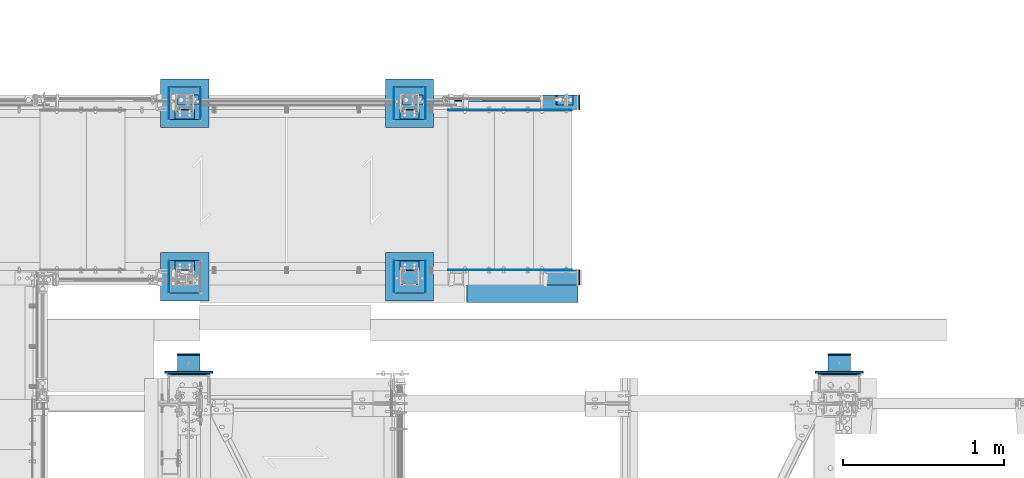
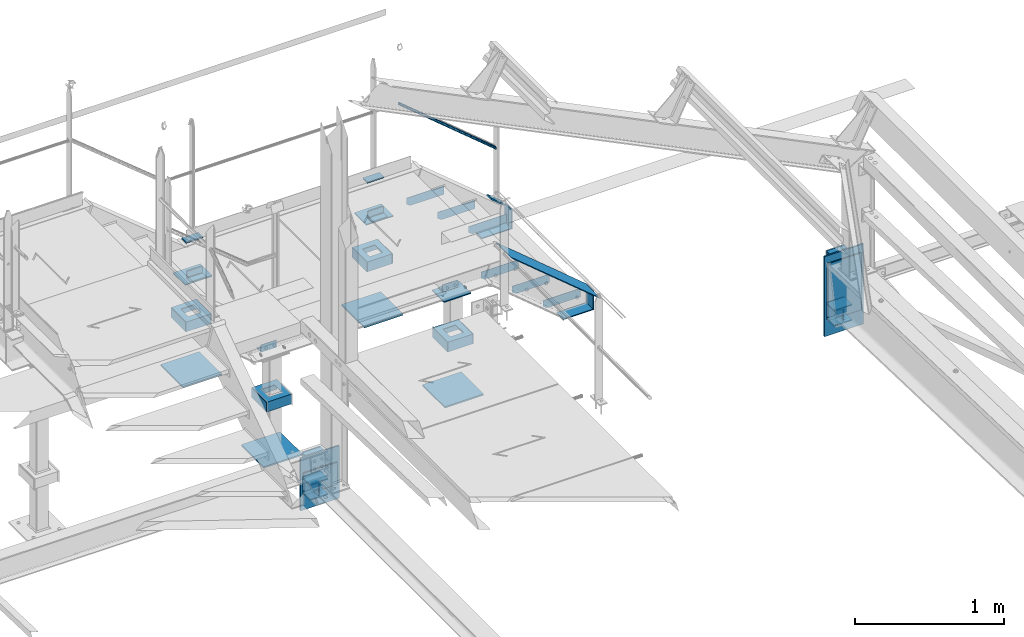
# One storey, part 114 of 496: 46 beams, 3 members, 19 elements without a shape of their own.
"""IFC2X3 building model written with IfcOpenShell, lengths in millimetres."""

from ifc_helpers import new_model, si_unit, frame, origin_with_axes, origin_2d_with_axis, place, context, subcontext, project, spatial, polyline, rectangle, hollow_circle, i_section, l_section, u_section, outline, extrude, boolean, clip, halfspace, material, type_object, element, aggregate, save


model = new_model("IFC2X3")

# Units and contexts
model_context = context("Model", 3, precision=1e-05, world=origin_with_axes())
body_context = subcontext(model_context, "Body", "Model", "MODEL_VIEW")
ifc_project = project(units=[si_unit("LENGTHUNIT", "METRE", prefix="MILLI"), si_unit("AREAUNIT", "SQUARE_METRE"), si_unit("VOLUMEUNIT", "CUBIC_METRE"), si_unit("MASSUNIT", "GRAM", prefix="KILO"), si_unit("TIMEUNIT", "SECOND"), si_unit("PLANEANGLEUNIT", "RADIAN"), si_unit("SOLIDANGLEUNIT", "STERADIAN"), si_unit("THERMODYNAMICTEMPERATUREUNIT", "DEGREE_CELSIUS"), si_unit("LUMINOUSINTENSITYUNIT", "LUMEN")], contexts=[model_context])

# Site, building, storey
site_placement = place(None, origin_with_axes())
site = spatial("IfcSite", under=ifc_project, at=site_placement, CompositionType="ELEMENT")
building_placement = place(site_placement, origin_with_axes())
building = spatial("IfcBuilding", under=site, at=building_placement, Name="Undefined", CompositionType="ELEMENT")
storey_placement = place(building_placement, origin_with_axes())
storey = spatial("IfcBuildingStorey", under=building, at=storey_placement, Name="Undefined", CompositionType="ELEMENT", Elevation=0.0)

# Assembly, member
assembly_1_placement = place(storey_placement, origin_with_axes())
assembly_1 = element("IfcElementAssembly", 1, at=assembly_1_placement, inside=storey, Name="VIDE", AssemblyPlace="NOTDEFINED", PredefinedType="NOTDEFINED")
ifc_material_1 = material(Name="Undefined/S235-E24")
member_type_1 = type_object("IfcMemberType", PredefinedType="NOTDEFINED")
member_1_placement = place(assembly_1_placement, frame((36702.1608014901, 15929.9998774163, 7532.9377228811), z_axis=(0.0, -1.0, 0.0), x_axis=(-0.768221279597376, 0.0, 0.640184399664479)))
member_1 = element("IfcMember", 2, at=member_1_placement, type_object=member_type_1, material=ifc_material_1, Name="VIDE", context=body_context, shape_type="SweptSolid", body=[
    extrude(rectangle(XDim=6.0, YDim=200.0, at=origin_2d_with_axis()), frame((900.000000001432, 9.99200722164227e-14, 0.0), z_axis=(-1.0, 0.0, 0.0), x_axis=(0.0, -1.0, 0.0)), (0.0, 0.0, 1.0), 900.0),
])
aggregate(assembly_1, [member_1])

# Assembly, beams, member
assembly_2_placement = place(storey_placement, origin_with_axes())
assembly_2 = element("IfcElementAssembly", 3, at=assembly_2_placement, inside=storey, Name="MAIN COURANTE", AssemblyPlace="NOTDEFINED", PredefinedType="NOTDEFINED")
beam_type_1 = type_object("IfcBeamType", PredefinedType="NOTDEFINED")
beam_1_placement = place(assembly_2_placement, frame((35740.0061849194, 17089.9938659712, 8114.9999407569), z_axis=(0.0, 1.0, 0.0), x_axis=(-1.0, 0.0, 0.0)))
beam_1 = element("IfcBeam", 4, at=beam_1_placement, type_object=beam_type_1, material=ifc_material_1, context=body_context, shape_type="SweptSolid", body=[
    extrude(rectangle(XDim=10.0, YDim=60.0, at=origin_2d_with_axis()), frame((130.0, 0.0, 0.0), z_axis=(-1.0, 0.0, 0.0), x_axis=(0.0, -1.0, 0.0)), (0.0, 0.0, 1.0), 130.0),
])
beam_2_placement = place(assembly_2_placement, frame((34340.0061849194, 17089.9938659712, 8114.9999407569), z_axis=(0.0, 1.0, 0.0), x_axis=(-1.0, 0.0, 0.0)))
beam_2 = element("IfcBeam", 5, at=beam_2_placement, type_object=beam_type_1, material=ifc_material_1, context=body_context, shape_type="SweptSolid", body=[
    extrude(rectangle(XDim=10.0, YDim=60.0, at=origin_2d_with_axis()), frame((130.0, 0.0, 0.0), z_axis=(-1.0, 0.0, 0.0), x_axis=(0.0, -1.0, 0.0)), (0.0, 0.0, 1.0), 130.0),
])
member_type_2 = type_object("IfcMemberType", PredefinedType="NOTDEFINED")
member_2_placement = place(assembly_2_placement, frame((36625.0061849194, 17089.9898795518, 8025.73196061016), z_axis=(0.0, -1.0, 0.0), x_axis=(-0.768221279597376, 0.0, 0.640184399664479)))
member_2 = element("IfcMember", 6, at=member_2_placement, type_object=member_type_2, material=ifc_material_1, Name="LISSE", context=body_context, shape_type="Clipping", body=[
    clip(clip(extrude(hollow_circle(Radius=10.64999962, WallThickness=2.0, at=origin_2d_with_axis()), frame((999.915375119574, 0.0, 0.0), z_axis=(-1.0, 0.0, 0.0), x_axis=(0.0, -1.0, 0.0)), (0.0, 0.0, 1.0), 1012.25), halfspace(frame((981.073731210257, -1.82259100256488e-07, -0.0039864193968242), z_axis=(-0.940271591821765, -0.340425224701349, 0.0), x_axis=(0.0, 0.0, -1.0)), True)), halfspace(frame((18.5934348061346, -14.5018748797629, -0.0039864193968242), z_axis=(-0.768221329187549, -0.640184340156267, 0.0), x_axis=(0.0, 0.0, -1.0)), False)),
])

# Assembly, beam
assembly_3_placement = place(storey_placement, origin_with_axes())
assembly_3 = element("IfcElementAssembly", 7, at=assembly_3_placement, inside=storey, AssemblyPlace="NOTDEFINED", PredefinedType="NOTDEFINED")
beam_type_2 = type_object("IfcBeamType", PredefinedType="NOTDEFINED")
beam_3_placement = place(assembly_3_placement, frame((34405.0000000001, 15839.9999136253, 7056.0), z_axis=(0.0, 0.0, -1.0), x_axis=(-1.0, 0.0, 0.0)))
beam_3 = element("IfcBeam", 8, at=beam_3_placement, type_object=beam_type_2, material=ifc_material_1, context=body_context, shape_type="SweptSolid", body=[
    extrude(outline(polyline([(0.0, 0.0), (300.0, 0.0), (300.0, 300.0), (0.0, 300.0), (0.0, 0.0)])), frame((0.0, 0.0, -6.0), z_axis=(0.0, 0.0, 1.0), x_axis=(1.0, 0.0, 0.0)), (0.0, 0.0, 1.0), 12.0),
])

assembly_4_placement = place(storey_placement, origin_with_axes())
assembly_4 = element("IfcElementAssembly", 9, at=assembly_4_placement, inside=storey, AssemblyPlace="NOTDEFINED", PredefinedType="NOTDEFINED")
beam_4_placement = place(assembly_4_placement, frame((35805.0000000001, 15839.9999136253, 7056.0), z_axis=(0.0, 0.0, -1.0), x_axis=(-1.0, 0.0, 0.0)))
beam_4 = element("IfcBeam", 10, at=beam_4_placement, type_object=beam_type_2, material=ifc_material_1, context=body_context, shape_type="SweptSolid", body=[
    extrude(outline(polyline([(0.0, 0.0), (300.0, 0.0), (300.0, 300.0), (0.0, 300.0), (0.0, 0.0)])), frame((0.0, 0.0, -6.0), z_axis=(0.0, 0.0, 1.0), x_axis=(1.0, 0.0, 0.0)), (0.0, 0.0, 1.0), 12.0),
])

assembly_5_placement = place(storey_placement, origin_with_axes())
assembly_5 = element("IfcElementAssembly", 11, at=assembly_5_placement, inside=storey, AssemblyPlace="NOTDEFINED", PredefinedType="NOTDEFINED")
beam_5_placement = place(assembly_5_placement, frame((34405.0000000001, 17219.9996684749, 7056.0), z_axis=(0.0, 0.0, 1.0), x_axis=(-1.0, 0.0, 0.0)))
beam_5 = element("IfcBeam", 12, at=beam_5_placement, type_object=beam_type_2, material=ifc_material_1, context=body_context, shape_type="SweptSolid", body=[
    extrude(outline(polyline([(0.0, 0.0), (300.0, 0.0), (300.0, 300.0), (0.0, 300.0), (0.0, 0.0)])), frame((0.0, 0.0, -6.0), z_axis=(0.0, 0.0, 1.0), x_axis=(1.0, 0.0, 0.0)), (0.0, 0.0, 1.0), 12.0),
])

assembly_6_placement = place(storey_placement, origin_with_axes())
assembly_6 = element("IfcElementAssembly", 13, at=assembly_6_placement, inside=storey, AssemblyPlace="NOTDEFINED", PredefinedType="NOTDEFINED")
beam_6_placement = place(assembly_6_placement, frame((35805.0000000001, 17219.9996684749, 7056.0), z_axis=(0.0, 0.0, 1.0), x_axis=(-1.0, 0.0, 0.0)))
beam_6 = element("IfcBeam", 14, at=beam_6_placement, type_object=beam_type_2, material=ifc_material_1, context=body_context, shape_type="SweptSolid", body=[
    extrude(outline(polyline([(0.0, 0.0), (300.0, 0.0), (300.0, 300.0), (0.0, 300.0), (0.0, 0.0)])), frame((0.0, 0.0, -6.0), z_axis=(0.0, 0.0, 1.0), x_axis=(1.0, 0.0, 0.0)), (0.0, 0.0, 1.0), 12.0),
])

assembly_7_placement = place(storey_placement, origin_with_axes())
assembly_7 = element("IfcElementAssembly", 15, at=assembly_7_placement, inside=storey, AssemblyPlace="NOTDEFINED", PredefinedType="NOTDEFINED")
beam_7_placement = place(assembly_7_placement, frame((34280.0000000012, 15395.9999999526, 7394.99830350895), z_axis=(-1.0, 0.0, 0.0), x_axis=(0.0, 0.0, -1.0)))
beam_7 = element("IfcBeam", 16, at=beam_7_placement, type_object=beam_type_2, material=ifc_material_1, context=body_context, shape_type="SweptSolid", body=[
    extrude(rectangle(XDim=12.0, YDim=300.0, at=origin_2d_with_axis()), frame((429.999999999754, 0.0, 0.0), z_axis=(-1.0, 0.0, 0.0), x_axis=(0.0, -1.0, 0.0)), (0.0, 0.0, 1.0), 430.0),
])

assembly_8_placement = place(storey_placement, origin_with_axes())
assembly_8 = element("IfcElementAssembly", 17, at=assembly_8_placement, inside=storey, AssemblyPlace="NOTDEFINED", PredefinedType="NOTDEFINED")
beam_8_placement = place(assembly_8_placement, frame((38330.0000000267, 15396.0000001713, 7624.99830350781), z_axis=(-1.0, 0.0, 0.0), x_axis=(0.0, 0.0, -1.0)))
beam_8 = element("IfcBeam", 18, at=beam_8_placement, type_object=beam_type_2, material=ifc_material_1, context=body_context, shape_type="SweptSolid", body=[
    extrude(rectangle(XDim=12.0, YDim=300.0, at=origin_2d_with_axis()), frame((654.999999999754, 0.0, 0.0), z_axis=(-1.0, 0.0, 0.0), x_axis=(0.0, -1.0, 0.0)), (0.0, 0.0, 1.0), 655.0),
])

# Member
member_type_3 = type_object("IfcMemberType", PredefinedType="NOTDEFINED")
member_3_placement = place(assembly_2_placement, frame((36667.8985396969, 17089.9938659712, 7564.09302426877), z_axis=(0.0, 1.0, 0.0), x_axis=(-0.768221279597376, 0.0, 0.640184399664479)))
member_3 = element("IfcMember", 19, at=member_3_placement, type_object=member_type_3, material=ifc_material_1, context=body_context, shape_type="SweptSolid", body=[
    extrude(rectangle(XDim=10.0, YDim=60.0, at=origin_2d_with_axis()), frame((130.0, 0.0, 0.0), z_axis=(-1.0, 0.0, 0.0), x_axis=(0.0, -1.0, 0.0)), (0.0, 0.0, 1.0), 130.0),
])

aggregate(assembly_2, [member_3, beam_1, beam_2, member_2])

# Beam
beam_type_3 = type_object("IfcBeamType", PredefinedType="NOTDEFINED")
beam_9_placement = place(assembly_4_placement, frame((35760.0000000001, 15930.0004325462, 7846.00001160755), z_axis=(0.0, 0.0, -1.0), x_axis=(-1.0, 0.0, 0.0)))
beam_9 = element("IfcBeam", 20, at=beam_9_placement, type_object=beam_type_3, material=ifc_material_1, context=body_context, shape_type="SweptSolid", body=[
    extrude(outline(polyline([(0.0, 0.0), (210.0, 0.0), (210.0, 159.999481201172), (0.0, 159.999481201172), (0.0, 0.0)])), frame((0.0, 0.0, -4.0), z_axis=(0.0, 0.0, 1.0), x_axis=(1.0, 0.0, 0.0)), (0.0, 0.0, 1.0), 8.0),
])

beam_10_placement = place(assembly_5_placement, frame((34360.0000000001, 17129.9991495539, 7846.00001160755), z_axis=(0.0, 0.0, 1.0), x_axis=(-1.0, 0.0, 0.0)))
beam_10 = element("IfcBeam", 21, at=beam_10_placement, type_object=beam_type_3, material=ifc_material_1, context=body_context, shape_type="SweptSolid", body=[
    extrude(outline(polyline([(0.0, 0.0), (210.0, 0.0), (210.0, 159.999481201172), (0.0, 159.999481201172), (0.0, 0.0)])), frame((0.0, 0.0, -4.0), z_axis=(0.0, 0.0, 1.0), x_axis=(1.0, 0.0, 0.0)), (0.0, 0.0, 1.0), 8.0),
])

beam_11_placement = place(assembly_6_placement, frame((35760.0000000001, 17129.9991495539, 7846.00001160755), z_axis=(0.0, 0.0, 1.0), x_axis=(-1.0, 0.0, 0.0)))
beam_11 = element("IfcBeam", 22, at=beam_11_placement, type_object=beam_type_3, material=ifc_material_1, context=body_context, shape_type="SweptSolid", body=[
    extrude(outline(polyline([(0.0, 0.0), (210.0, 0.0), (210.0, 159.999481201172), (0.0, 159.999481201172), (0.0, 0.0)])), frame((0.0, 0.0, -4.0), z_axis=(0.0, 0.0, 1.0), x_axis=(1.0, 0.0, 0.0)), (0.0, 0.0, 1.0), 8.0),
])

beam_type_4 = type_object("IfcBeamType", PredefinedType="NOTDEFINED")
beam_12_placement = place(assembly_4_placement, frame((35753.0000000001, 16089.9999136253, 7500.0), z_axis=(0.0, 0.0, 1.0), x_axis=(0.0, -1.0, 0.0)))
beam_12 = element("IfcBeam", 23, at=beam_12_placement, type_object=beam_type_4, material=ifc_material_1, Name="BORD", context=body_context, shape_type="SweptSolid", body=[
    extrude(rectangle(XDim=4.0, YDim=80.0, at=origin_2d_with_axis()), frame((200.0, 0.0, 0.0), z_axis=(-1.0, 0.0, 0.0), x_axis=(0.0, -1.0, 0.0)), (0.0, 0.0, 1.0), 200.0),
])

beam_13_placement = place(assembly_3_placement, frame((34157.0000000001, 16089.9999136253, 7500.0), z_axis=(0.0, 0.0, 1.0), x_axis=(0.0, -1.0, 0.0)))
beam_13 = element("IfcBeam", 24, at=beam_13_placement, type_object=beam_type_4, material=ifc_material_1, Name="BORD", context=body_context, shape_type="SweptSolid", body=[
    extrude(rectangle(XDim=4.0, YDim=80.0, at=origin_2d_with_axis()), frame((200.0, 0.0, 0.0), z_axis=(-1.0, 0.0, 0.0), x_axis=(0.0, -1.0, 0.0)), (0.0, 0.0, 1.0), 200.0),
])

beam_14_placement = place(assembly_4_placement, frame((35557.0000000001, 16089.9999136253, 7500.0), z_axis=(0.0, 0.0, 1.0), x_axis=(0.0, -1.0, 0.0)))
beam_14 = element("IfcBeam", 25, at=beam_14_placement, type_object=beam_type_4, material=ifc_material_1, Name="BORD", context=body_context, shape_type="SweptSolid", body=[
    extrude(rectangle(XDim=4.0, YDim=80.0, at=origin_2d_with_axis()), frame((200.0, 0.0, 0.0), z_axis=(-1.0, 0.0, 0.0), x_axis=(0.0, -1.0, 0.0)), (0.0, 0.0, 1.0), 200.0),
])

beam_15_placement = place(assembly_5_placement, frame((34353.0000000001, 16969.9996684749, 7500.0), z_axis=(0.0, 0.0, 1.0), x_axis=(0.0, 1.0, 0.0)))
beam_15 = element("IfcBeam", 26, at=beam_15_placement, type_object=beam_type_4, material=ifc_material_1, Name="BORD", context=body_context, shape_type="SweptSolid", body=[
    extrude(rectangle(XDim=4.0, YDim=80.0, at=origin_2d_with_axis()), frame((200.0, 0.0, 0.0), z_axis=(-1.0, 0.0, 0.0), x_axis=(0.0, -1.0, 0.0)), (0.0, 0.0, 1.0), 200.0),
])

beam_16_placement = place(assembly_6_placement, frame((35753.0000000001, 16969.9996684749, 7500.0), z_axis=(0.0, 0.0, 1.0), x_axis=(0.0, 1.0, 0.0)))
beam_16 = element("IfcBeam", 27, at=beam_16_placement, type_object=beam_type_4, material=ifc_material_1, Name="BORD", context=body_context, shape_type="SweptSolid", body=[
    extrude(rectangle(XDim=4.0, YDim=80.0, at=origin_2d_with_axis()), frame((200.0, 0.0, 0.0), z_axis=(-1.0, 0.0, 0.0), x_axis=(0.0, -1.0, 0.0)), (0.0, 0.0, 1.0), 200.0),
])

beam_17_placement = place(assembly_5_placement, frame((34157.0000000001, 16969.9996684749, 7500.0), z_axis=(0.0, 0.0, 1.0), x_axis=(0.0, 1.0, 0.0)))
beam_17 = element("IfcBeam", 28, at=beam_17_placement, type_object=beam_type_4, material=ifc_material_1, Name="BORD", context=body_context, shape_type="SweptSolid", body=[
    extrude(rectangle(XDim=4.0, YDim=80.0, at=origin_2d_with_axis()), frame((200.0, 0.0, 0.0), z_axis=(-1.0, 0.0, 0.0), x_axis=(0.0, -1.0, 0.0)), (0.0, 0.0, 1.0), 200.0),
])

beam_18_placement = place(assembly_6_placement, frame((35557.0000000001, 16969.9996684749, 7500.0), z_axis=(0.0, 0.0, 1.0), x_axis=(0.0, 1.0, 0.0)))
beam_18 = element("IfcBeam", 29, at=beam_18_placement, type_object=beam_type_4, material=ifc_material_1, Name="BORD", context=body_context, shape_type="SweptSolid", body=[
    extrude(rectangle(XDim=4.0, YDim=80.0, at=origin_2d_with_axis()), frame((200.0, 0.0, 0.0), z_axis=(-1.0, 0.0, 0.0), x_axis=(0.0, -1.0, 0.0)), (0.0, 0.0, 1.0), 200.0),
])

beam_type_5 = type_object("IfcBeamType", PredefinedType="NOTDEFINED")
beam_19_placement = place(assembly_3_placement, frame((34351.0000000001, 15989.9999136253, 7500.0), z_axis=(0.0, 1.0, 0.0), x_axis=(-1.0, 0.0, 0.0)))
beam_19 = element("IfcBeam", 30, at=beam_19_placement, type_object=beam_type_5, material=ifc_material_1, context=body_context, shape_type="CSG", body=[
    boolean("DIFFERENCE", extrude(u_section(Depth=200.0, FlangeWidth=80.0, WebThickness=4.0, FlangeThickness=4.0, at=origin_2d_with_axis()), frame((192.0, 0.0, 0.0), z_axis=(-1.0, 0.0, 0.0), x_axis=(0.0, -1.0, 0.0)), (0.0, 0.0, 1.0), 192.0), extrude(outline(polyline([(0.0, 0.0), (101.0, 0.0), (101.0, 101.0), (0.0, 101.0), (0.0, 0.0)])), frame((146.5, -42.5, 50.5), z_axis=(0.0, 1.0, 0.0), x_axis=(0.0, 0.0, -1.0)), (0.0, 0.0, 1.0), 85.0)),
])

aggregate(assembly_3, [beam_13, beam_19, beam_3])

beam_20_placement = place(assembly_4_placement, frame((35751.0000000001, 15989.9999136253, 7500.0), z_axis=(0.0, 1.0, 0.0), x_axis=(-1.0, 0.0, 0.0)))
beam_20 = element("IfcBeam", 31, at=beam_20_placement, type_object=beam_type_5, material=ifc_material_1, context=body_context, shape_type="CSG", body=[
    boolean("DIFFERENCE", extrude(u_section(Depth=200.0, FlangeWidth=80.0, WebThickness=4.0, FlangeThickness=4.0, at=origin_2d_with_axis()), frame((192.0, 0.0, 0.0), z_axis=(-1.0, 0.0, 0.0), x_axis=(0.0, -1.0, 0.0)), (0.0, 0.0, 1.0), 192.0), extrude(outline(polyline([(0.0, 0.0), (101.0, 0.0), (101.0, 101.0), (0.0, 101.0), (0.0, 0.0)])), frame((146.5, -42.5, 50.5), z_axis=(0.0, 1.0, 0.0), x_axis=(0.0, 0.0, -1.0)), (0.0, 0.0, 1.0), 85.0)),
])

aggregate(assembly_4, [beam_12, beam_9, beam_14, beam_20, beam_4])

beam_21_placement = place(assembly_5_placement, frame((34159.0000000001, 17069.9996684749, 7500.0), z_axis=(0.0, -1.0, 0.0), x_axis=(1.0, 0.0, 0.0)))
beam_21 = element("IfcBeam", 32, at=beam_21_placement, type_object=beam_type_5, material=ifc_material_1, context=body_context, shape_type="CSG", body=[
    boolean("DIFFERENCE", extrude(u_section(Depth=200.0, FlangeWidth=80.0, WebThickness=4.0, FlangeThickness=4.0, at=origin_2d_with_axis()), frame((192.0, 0.0, 0.0), z_axis=(-1.0, 0.0, 0.0), x_axis=(0.0, -1.0, 0.0)), (0.0, 0.0, 1.0), 192.0), extrude(outline(polyline([(0.0, 0.0), (101.0, 0.0), (101.0, 101.0), (0.0, 101.0), (0.0, 0.0)])), frame((45.5, -42.5, -50.5), z_axis=(0.0, 1.0, 0.0), x_axis=(0.0, 0.0, 1.0)), (0.0, 0.0, 1.0), 85.0)),
])

aggregate(assembly_5, [beam_10, beam_15, beam_17, beam_21, beam_5])

beam_22_placement = place(assembly_6_placement, frame((35559.0000000001, 17069.9996684749, 7500.0), z_axis=(0.0, -1.0, 0.0), x_axis=(1.0, 0.0, 0.0)))
beam_22 = element("IfcBeam", 33, at=beam_22_placement, type_object=beam_type_5, material=ifc_material_1, context=body_context, shape_type="CSG", body=[
    boolean("DIFFERENCE", extrude(u_section(Depth=200.0, FlangeWidth=80.0, WebThickness=4.0, FlangeThickness=4.0, at=origin_2d_with_axis()), frame((192.0, 0.0, 0.0), z_axis=(-1.0, 0.0, 0.0), x_axis=(0.0, -1.0, 0.0)), (0.0, 0.0, 1.0), 192.0), extrude(outline(polyline([(0.0, 0.0), (101.0, 0.0), (101.0, 101.0), (0.0, 101.0), (0.0, 0.0)])), frame((45.5, -42.5, -50.5), z_axis=(0.0, 1.0, 0.0), x_axis=(0.0, 0.0, 1.0)), (0.0, 0.0, 1.0), 85.0)),
])

aggregate(assembly_6, [beam_16, beam_11, beam_18, beam_22, beam_6])

# Assembly, beams
assembly_9_placement = place(storey_placement, origin_with_axes())
assembly_9 = element("IfcElementAssembly", 34, at=assembly_9_placement, inside=storey, AssemblyPlace="NOTDEFINED", PredefinedType="NOTDEFINED")
beam_type_6 = type_object("IfcBeamType", PredefinedType="NOTDEFINED")
beam_23_placement = place(assembly_9_placement, frame((36714.9999902344, 15984.9996684858, 7373.99994075732), z_axis=(0.0, -1.0, 0.0), x_axis=(-1.0, 0.0, 0.0)))
beam_23 = element("IfcBeam", 35, at=beam_23_placement, type_object=beam_type_6, material=ifc_material_1, Name="PLAT", context=body_context, shape_type="SweptSolid", body=[
    extrude(rectangle(XDim=8.0, YDim=90.0, at=origin_2d_with_axis()), frame((237.732983147944, 0.0, 0.0), z_axis=(-1.0, 0.0, 0.0), x_axis=(0.0, -1.0, 0.0)), (0.0, 0.0, 1.0), 237.73),
])
beam_24_placement = place(assembly_9_placement, frame((36710.9999902344, 15984.9996684858, 7524.9999407576), z_axis=(0.0, -1.0, 0.0), x_axis=(0.0, 0.0, -1.0)))
beam_24 = element("IfcBeam", 36, at=beam_24_placement, type_object=beam_type_6, material=ifc_material_1, Name="PLAT", context=body_context, shape_type="SweptSolid", body=[
    extrude(rectangle(XDim=8.0, YDim=90.0, at=origin_2d_with_axis()), frame((147.00000000028, 0.0, 0.0), z_axis=(-1.0, 0.0, 0.0), x_axis=(0.0, -1.0, 0.0)), (0.0, 0.0, 1.0), 147.0),
])
aggregate(assembly_9, [beam_23, beam_24])

assembly_10_placement = place(storey_placement, origin_with_axes())
assembly_10 = element("IfcElementAssembly", 37, at=assembly_10_placement, inside=storey, AssemblyPlace="NOTDEFINED", PredefinedType="NOTDEFINED")
beam_25_placement = place(assembly_10_placement, frame((36714.9999902344, 17074.9996684893, 7373.99994075732), z_axis=(0.0, 1.0, 0.0), x_axis=(-1.0, 0.0, 0.0)))
beam_25 = element("IfcBeam", 38, at=beam_25_placement, type_object=beam_type_6, material=ifc_material_1, Name="PLAT", context=body_context, shape_type="SweptSolid", body=[
    extrude(rectangle(XDim=8.0, YDim=90.0, at=origin_2d_with_axis()), frame((237.732983147944, 0.0, 0.0), z_axis=(-1.0, 0.0, 0.0), x_axis=(0.0, -1.0, 0.0)), (0.0, 0.0, 1.0), 237.73),
])
beam_26_placement = place(assembly_10_placement, frame((36710.9999902344, 17074.9996684893, 7524.9999407576), z_axis=(0.0, 1.0, 0.0), x_axis=(0.0, 0.0, -1.0)))
beam_26 = element("IfcBeam", 39, at=beam_26_placement, type_object=beam_type_6, material=ifc_material_1, Name="PLAT", context=body_context, shape_type="SweptSolid", body=[
    extrude(rectangle(XDim=8.0, YDim=90.0, at=origin_2d_with_axis()), frame((147.00000000028, 0.0, 0.0), z_axis=(-1.0, 0.0, 0.0), x_axis=(0.0, -1.0, 0.0)), (0.0, 0.0, 1.0), 147.0),
])
aggregate(assembly_10, [beam_25, beam_26])

assembly_11_placement = place(storey_placement, origin_with_axes())
assembly_11 = element("IfcElementAssembly", 40, at=assembly_11_placement, inside=storey, Name="MARCHE", AssemblyPlace="NOTDEFINED", PredefinedType="NOTDEFINED")
beam_type_7 = type_object("IfcBeamType", PredefinedType="NOTDEFINED")
beam_27_placement = place(assembly_11_placement, frame((36184.9999902344, 17028.4999136338, 7909.9999407569), z_axis=(0.0, 1.0, 0.0), x_axis=(0.0, 0.0, -1.0)))
beam_27 = element("IfcBeam", 41, at=beam_27_placement, type_object=beam_type_7, material=ifc_material_1, Name="PLAT MARCHE", context=body_context, shape_type="SweptSolid", body=[
    extrude(outline(polyline([(0.0, 0.0), (70.0, 0.0), (70.0, 260.0), (50.0, 290.0), (0.0, 290.0), (0.0, 0.0)])), frame((0.0, 0.0, -1.5), z_axis=(0.0, 0.0, 1.0), x_axis=(1.0, 0.0, 0.0)), (0.0, 0.0, 1.0), 3.0),
])
beam_28_placement = place(assembly_11_placement, frame((36184.9999902344, 16031.4996684663, 7909.9999407569), z_axis=(0.0, 1.0, 0.0), x_axis=(0.0, 0.0, -1.0)))
beam_28 = element("IfcBeam", 42, at=beam_28_placement, type_object=beam_type_7, material=ifc_material_1, Name="PLAT MARCHE", context=body_context, shape_type="SweptSolid", body=[
    extrude(outline(polyline([(0.0, 0.0), (70.0, 0.0), (70.0, 260.0), (50.0, 290.0), (0.0, 290.0), (0.0, 0.0)])), frame((0.0, 0.0, -1.5), z_axis=(0.0, 0.0, 1.0), x_axis=(1.0, 0.0, 0.0)), (0.0, 0.0, 1.0), 3.0),
])
aggregate(assembly_11, [beam_27, beam_28])

assembly_12_placement = place(storey_placement, origin_with_axes())
assembly_12 = element("IfcElementAssembly", 43, at=assembly_12_placement, inside=storey, Name="MARCHE", AssemblyPlace="NOTDEFINED", PredefinedType="NOTDEFINED")
beam_29_placement = place(assembly_12_placement, frame((36424.9999902344, 17028.4999136338, 7710.0), z_axis=(0.0, 1.0, 0.0), x_axis=(0.0, 0.0, -1.0)))
beam_29 = element("IfcBeam", 44, at=beam_29_placement, type_object=beam_type_7, material=ifc_material_1, Name="PLAT MARCHE", context=body_context, shape_type="SweptSolid", body=[
    extrude(outline(polyline([(0.0, 0.0), (70.0, 0.0), (70.0, 260.0), (50.0, 290.0), (0.0, 290.0), (0.0, 0.0)])), frame((0.0, 0.0, -1.5), z_axis=(0.0, 0.0, 1.0), x_axis=(1.0, 0.0, 0.0)), (0.0, 0.0, 1.0), 3.0),
])
beam_30_placement = place(assembly_12_placement, frame((36424.9999902344, 16031.4996684663, 7710.0), z_axis=(0.0, 1.0, 0.0), x_axis=(0.0, 0.0, -1.0)))
beam_30 = element("IfcBeam", 45, at=beam_30_placement, type_object=beam_type_7, material=ifc_material_1, Name="PLAT MARCHE", context=body_context, shape_type="SweptSolid", body=[
    extrude(outline(polyline([(0.0, 0.0), (70.0, 0.0), (70.0, 260.0), (50.0, 290.0), (0.0, 290.0), (0.0, 0.0)])), frame((0.0, 0.0, -1.5), z_axis=(0.0, 0.0, 1.0), x_axis=(1.0, 0.0, 0.0)), (0.0, 0.0, 1.0), 3.0),
])
aggregate(assembly_12, [beam_29, beam_30])

assembly_13_placement = place(storey_placement, origin_with_axes())
assembly_13 = element("IfcElementAssembly", 46, at=assembly_13_placement, inside=storey, Name="MARCHE", AssemblyPlace="NOTDEFINED", PredefinedType="NOTDEFINED")
beam_31_placement = place(assembly_13_placement, frame((36664.9999902344, 17028.4999136338, 7510.0), z_axis=(0.0, 1.0, 0.0), x_axis=(0.0, 0.0, -1.0)))
beam_31 = element("IfcBeam", 47, at=beam_31_placement, type_object=beam_type_7, material=ifc_material_1, Name="PLAT MARCHE", context=body_context, shape_type="SweptSolid", body=[
    extrude(outline(polyline([(0.0, 0.0), (70.0, 0.0), (70.0, 260.0), (50.0, 290.0), (0.0, 290.0), (0.0, 0.0)])), frame((0.0, 0.0, -1.5), z_axis=(0.0, 0.0, 1.0), x_axis=(1.0, 0.0, 0.0)), (0.0, 0.0, 1.0), 3.0),
])
beam_32_placement = place(assembly_13_placement, frame((36664.9999902344, 16031.4996684663, 7510.0), z_axis=(0.0, 1.0, 0.0), x_axis=(0.0, 0.0, -1.0)))
beam_32 = element("IfcBeam", 48, at=beam_32_placement, type_object=beam_type_7, material=ifc_material_1, Name="PLAT MARCHE", context=body_context, shape_type="SweptSolid", body=[
    extrude(outline(polyline([(0.0, 0.0), (70.0, 0.0), (70.0, 260.0), (50.0, 290.0), (0.0, 290.0), (0.0, 0.0)])), frame((0.0, 0.0, -1.5), z_axis=(0.0, 0.0, 1.0), x_axis=(1.0, 0.0, 0.0)), (0.0, 0.0, 1.0), 3.0),
])
aggregate(assembly_13, [beam_31, beam_32])

# Assembly, beam
assembly_14_placement = place(storey_placement, origin_with_axes())
assembly_14 = element("IfcElementAssembly", 49, at=assembly_14_placement, inside=storey, AssemblyPlace="NOTDEFINED", PredefinedType="NOTDEFINED")
beam_type_8 = type_object("IfcBeamType", PredefinedType="NOTDEFINED")
beam_33_placement = place(assembly_14_placement, frame((34315.0000000001, 16059.9999136126, 7879.9999407569), z_axis=(0.0, 0.0, 1.0), x_axis=(-1.0, 0.0, 0.0)))
beam_33 = element("IfcBeam", 50, at=beam_33_placement, type_object=beam_type_8, material=ifc_material_1, context=body_context, shape_type="SweptSolid", body=[
    extrude(l_section(Depth=60.0, Width=60.0, Thickness=6.0, FilletRadius=8.0, EdgeRadius=4.0, at=origin_2d_with_axis()), frame((120.0, 0.0, 0.0), z_axis=(-1.0, 0.0, 0.0), x_axis=(0.0, -1.0, 0.0)), (0.0, 0.0, 1.0), 120.0),
])
aggregate(assembly_14, [beam_33])

assembly_15_placement = place(storey_placement, origin_with_axes())
assembly_15 = element("IfcElementAssembly", 51, at=assembly_15_placement, inside=storey, AssemblyPlace="NOTDEFINED", PredefinedType="NOTDEFINED")
beam_34_placement = place(assembly_15_placement, frame((35715.0000000001, 16059.9999136126, 7879.9999407569), z_axis=(0.0, 0.0, 1.0), x_axis=(-1.0, 0.0, 0.0)))
beam_34 = element("IfcBeam", 52, at=beam_34_placement, type_object=beam_type_8, material=ifc_material_1, context=body_context, shape_type="SweptSolid", body=[
    extrude(l_section(Depth=60.0, Width=60.0, Thickness=6.0, FilletRadius=8.0, EdgeRadius=4.0, at=origin_2d_with_axis()), frame((120.0, 0.0, 0.0), z_axis=(-1.0, 0.0, 0.0), x_axis=(0.0, -1.0, 0.0)), (0.0, 0.0, 1.0), 120.0),
])
aggregate(assembly_15, [beam_34])

assembly_16_placement = place(storey_placement, origin_with_axes())
assembly_16 = element("IfcElementAssembly", 53, at=assembly_16_placement, inside=storey, AssemblyPlace="NOTDEFINED", PredefinedType="NOTDEFINED")
beam_35_placement = place(assembly_16_placement, frame((34195.0000000001, 16999.9996684876, 7879.9999407569), z_axis=(0.0, 0.0, 1.0), x_axis=(1.0, 0.0, 0.0)))
beam_35 = element("IfcBeam", 54, at=beam_35_placement, type_object=beam_type_8, material=ifc_material_1, context=body_context, shape_type="SweptSolid", body=[
    extrude(l_section(Depth=60.0, Width=60.0, Thickness=6.0, FilletRadius=8.0, EdgeRadius=4.0, at=origin_2d_with_axis()), frame((120.0, 0.0, 0.0), z_axis=(-1.0, 0.0, 0.0), x_axis=(0.0, -1.0, 0.0)), (0.0, 0.0, 1.0), 120.0),
])
aggregate(assembly_16, [beam_35])

assembly_17_placement = place(storey_placement, origin_with_axes())
assembly_17 = element("IfcElementAssembly", 55, at=assembly_17_placement, inside=storey, AssemblyPlace="NOTDEFINED", PredefinedType="NOTDEFINED")
beam_36_placement = place(assembly_17_placement, frame((35595.0000000001, 16999.9996684876, 7879.9999407569), z_axis=(0.0, 0.0, 1.0), x_axis=(1.0, 0.0, 0.0)))
beam_36 = element("IfcBeam", 56, at=beam_36_placement, type_object=beam_type_8, material=ifc_material_1, context=body_context, shape_type="SweptSolid", body=[
    extrude(l_section(Depth=60.0, Width=60.0, Thickness=6.0, FilletRadius=8.0, EdgeRadius=4.0, at=origin_2d_with_axis()), frame((120.0, 0.0, 0.0), z_axis=(-1.0, 0.0, 0.0), x_axis=(0.0, -1.0, 0.0)), (0.0, 0.0, 1.0), 120.0),
])
aggregate(assembly_17, [beam_36])

# Beam
beam_type_9 = type_object("IfcBeamType", PredefinedType="NOTDEFINED")
beam_37_placement = place(assembly_7_placement, frame((34280.0000000043, 15507.0000000607, 7146.49830350798), z_axis=(-1.0, 0.0, 0.0), x_axis=(0.0, 0.0, -1.0)))
beam_37 = element("IfcBeam", 57, at=beam_37_placement, type_object=beam_type_9, material=ifc_material_1, Name="PLAT", context=body_context, shape_type="SweptSolid", body=[
    extrude(rectangle(XDim=10.0, YDim=140.0, at=origin_2d_with_axis()), frame((132.999999999945, 0.0, 0.0), z_axis=(-1.0, 0.0, 0.0), x_axis=(0.0, -1.0, 0.0)), (0.0, 0.0, 1.0), 133.0),
])

beam_38_placement = place(assembly_7_placement, frame((34280.0000000043, 15507.0000000349, 7346.49830350782), z_axis=(-1.0, 0.0, 0.0), x_axis=(0.0, 0.0, -1.0)))
beam_38 = element("IfcBeam", 58, at=beam_38_placement, type_object=beam_type_9, material=ifc_material_1, Name="PLAT", context=body_context, shape_type="SweptSolid", body=[
    extrude(rectangle(XDim=10.0, YDim=140.0, at=origin_2d_with_axis()), frame((132.999999999945, 0.0, 0.0), z_axis=(-1.0, 0.0, 0.0), x_axis=(0.0, -1.0, 0.0)), (0.0, 0.0, 1.0), 133.0),
])

beam_39_placement = place(assembly_8_placement, frame((38330.0000000283, 15507.0000002057, 7151.49830350798), z_axis=(-1.0, 0.0, 0.0), x_axis=(0.0, 0.0, -1.0)))
beam_39 = element("IfcBeam", 59, at=beam_39_placement, type_object=beam_type_9, material=ifc_material_1, Name="PLAT", context=body_context, shape_type="SweptSolid", body=[
    extrude(rectangle(XDim=10.0, YDim=140.0, at=origin_2d_with_axis()), frame((132.999999999945, 0.0, 0.0), z_axis=(-1.0, 0.0, 0.0), x_axis=(0.0, -1.0, 0.0)), (0.0, 0.0, 1.0), 133.0),
])

beam_40_placement = place(assembly_8_placement, frame((38330.0000000282, 15507.0000002056, 7576.49830350782), z_axis=(-1.0, 0.0, 0.0), x_axis=(0.0, 0.0, -1.0)))
beam_40 = element("IfcBeam", 60, at=beam_40_placement, type_object=beam_type_9, material=ifc_material_1, Name="PLAT", context=body_context, shape_type="SweptSolid", body=[
    extrude(rectangle(XDim=10.0, YDim=140.0, at=origin_2d_with_axis()), frame((132.999999999945, 0.0, 0.0), z_axis=(-1.0, 0.0, 0.0), x_axis=(0.0, -1.0, 0.0)), (0.0, 0.0, 1.0), 133.0),
])

ifc_material_2 = material(Name="Undefined/S275-E28")
beam_type_10 = type_object("IfcBeamType", Name="HEA140", PredefinedType="NOTDEFINED")
beam_41_placement = place(assembly_7_placement, frame((34280.000000002, 15402.0000000605, 7079.99830350799), z_axis=(0.0, 0.0, 1.0), x_axis=(0.0, 1.0, 0.0)))
beam_41 = element("IfcBeam", 61, at=beam_41_placement, type_object=beam_type_10, material=ifc_material_2, ObjectType="HEA140", context=body_context, shape_type="SweptSolid", body=[
    extrude(i_section(OverallWidth=140.0, OverallDepth=133.0, WebThickness=5.5, FlangeThickness=8.5, FilletRadius=12.0, at=origin_2d_with_axis()), frame((100.000000000021, 5.72981662116945e-11, -4.09272615797818e-12), z_axis=(-1.0, 0.0, 0.0), x_axis=(0.0, -1.0, 0.0)), (0.0, 0.0, 1.0), 100.0),
])

beam_42_placement = place(assembly_7_placement, frame((34280.0000000019, 15402.0000000347, 7279.99830350785), z_axis=(0.0, 0.0, 1.0), x_axis=(0.0, 1.0, 0.0)))
beam_42 = element("IfcBeam", 62, at=beam_42_placement, type_object=beam_type_10, material=ifc_material_2, ObjectType="HEA140", context=body_context, shape_type="SweptSolid", body=[
    extrude(i_section(OverallWidth=140.0, OverallDepth=133.0, WebThickness=5.5, FlangeThickness=8.5, FilletRadius=12.0, at=origin_2d_with_axis()), frame((100.000000000021, 5.72981662116945e-11, -4.09272615797818e-12), z_axis=(-1.0, 0.0, 0.0), x_axis=(0.0, -1.0, 0.0)), (0.0, 0.0, 1.0), 100.0),
])

aggregate(assembly_7, [beam_37, beam_41, beam_38, beam_42, beam_7])

beam_43_placement = place(assembly_8_placement, frame((38330.0000000266, 15402.0000002055, 7084.99830350799), z_axis=(0.0, 0.0, 1.0), x_axis=(0.0, 1.0, 0.0)))
beam_43 = element("IfcBeam", 63, at=beam_43_placement, type_object=beam_type_10, material=ifc_material_2, ObjectType="HEA140", context=body_context, shape_type="SweptSolid", body=[
    extrude(i_section(OverallWidth=140.0, OverallDepth=133.0, WebThickness=5.5, FlangeThickness=8.5, FilletRadius=12.0, at=origin_2d_with_axis()), frame((100.000000000021, 5.72981662116945e-11, -4.09272615797818e-12), z_axis=(-1.0, 0.0, 0.0), x_axis=(0.0, -1.0, 0.0)), (0.0, 0.0, 1.0), 100.0),
])

beam_44_placement = place(assembly_8_placement, frame((38330.0000000267, 15402.0000002054, 7509.99830350785), z_axis=(0.0, 0.0, 1.0), x_axis=(0.0, 1.0, 0.0)))
beam_44 = element("IfcBeam", 64, at=beam_44_placement, type_object=beam_type_10, material=ifc_material_2, ObjectType="HEA140", context=body_context, shape_type="SweptSolid", body=[
    extrude(i_section(OverallWidth=140.0, OverallDepth=133.0, WebThickness=5.5, FlangeThickness=8.5, FilletRadius=12.0, at=origin_2d_with_axis()), frame((100.000000000021, 5.72981662116945e-11, -4.09272615797818e-12), z_axis=(-1.0, 0.0, 0.0), x_axis=(0.0, -1.0, 0.0)), (0.0, 0.0, 1.0), 100.0),
])

aggregate(assembly_8, [beam_39, beam_43, beam_40, beam_44, beam_8])

# Assembly, beam
assembly_18_placement = place(storey_placement, origin_with_axes())
assembly_18 = element("IfcElementAssembly", 65, at=assembly_18_placement, inside=storey, AssemblyPlace="NOTDEFINED", PredefinedType="NOTDEFINED")
beam_type_11 = type_object("IfcBeamType", PredefinedType="NOTDEFINED")
beam_45_placement = place(assembly_18_placement, frame((34279.9999999986, 15385.0000003326, 7271.99914127214), z_axis=(-1.0, 0.0, 0.0), x_axis=(0.0, 0.0, -1.0)))
beam_45 = element("IfcBeam", 66, at=beam_45_placement, type_object=beam_type_11, material=ifc_material_1, context=body_context, shape_type="SweptSolid", body=[
    extrude(rectangle(XDim=10.0, YDim=260.0, at=origin_2d_with_axis()), frame((180.000836427161, 0.0, 0.0), z_axis=(-1.0, 0.0, 0.0), x_axis=(0.0, -1.0, 0.0)), (0.0, 0.0, 1.0), 180.0),
])
aggregate(assembly_18, [beam_45])

assembly_19_placement = place(storey_placement, origin_with_axes())
assembly_19 = element("IfcElementAssembly", 67, at=assembly_19_placement, inside=storey, AssemblyPlace="NOTDEFINED", PredefinedType="NOTDEFINED")
beam_46_placement = place(assembly_19_placement, frame((38330.0000000248, 15385.0000006166, 7564.99670315622), z_axis=(-1.0, 0.0, 0.0), x_axis=(0.0, 0.0, -1.0)))
beam_46 = element("IfcBeam", 68, at=beam_46_placement, type_object=beam_type_11, material=ifc_material_1, context=body_context, shape_type="SweptSolid", body=[
    extrude(rectangle(XDim=10.0, YDim=260.0, at=origin_2d_with_axis()), frame((464.999999999777, 0.0, 0.0), z_axis=(-1.0, 0.0, 0.0), x_axis=(0.0, -1.0, 0.0)), (0.0, 0.0, 1.0), 465.0),
])
aggregate(assembly_19, [beam_46])

save(model, "model.ifc")
